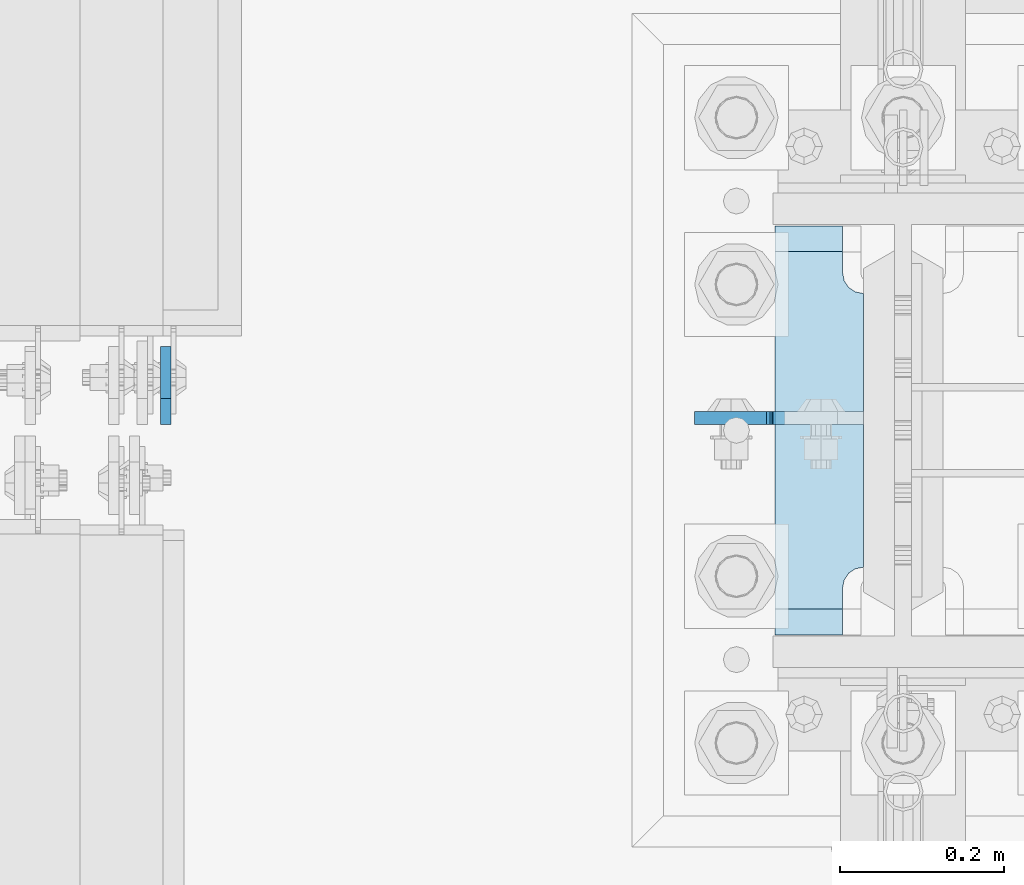
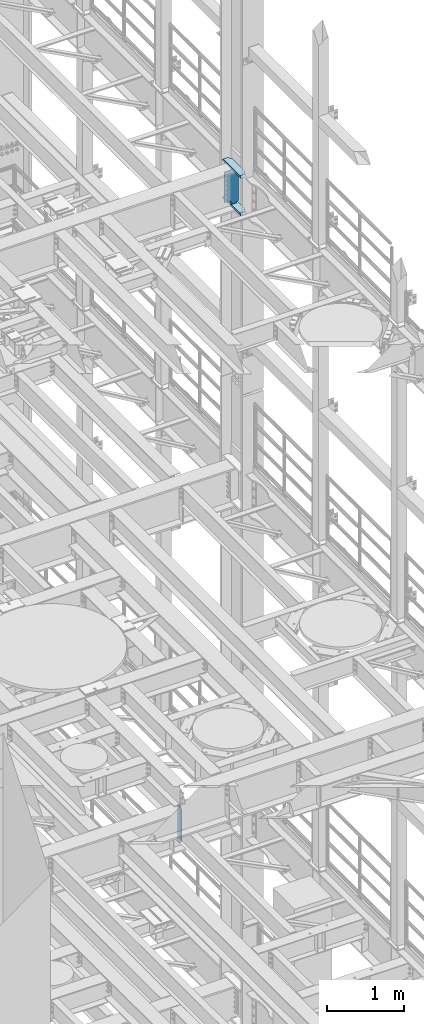
# One storey, part 1734 of 1876: 4 plates, 2 elements without a shape of their own.
"""IFC2X3 building model written with IfcOpenShell, lengths in millimetres."""

from ifc_helpers import new_model, si_unit, frame, origin_with_axes, place, context, subcontext, project, spatial, faceted_brep, material, type_object, element, aggregate, save


model = new_model("IFC2X3")

# Units and contexts
model_context = context("Model", 3, precision=1e-05, world=origin_with_axes())
body_context = subcontext(model_context, "Body", "Model", "MODEL_VIEW")
ifc_project = project(units=[si_unit("LENGTHUNIT", "METRE", prefix="MILLI"), si_unit("AREAUNIT", "SQUARE_METRE"), si_unit("VOLUMEUNIT", "CUBIC_METRE"), si_unit("MASSUNIT", "GRAM", prefix="KILO"), si_unit("TIMEUNIT", "SECOND"), si_unit("PLANEANGLEUNIT", "RADIAN"), si_unit("SOLIDANGLEUNIT", "STERADIAN"), si_unit("THERMODYNAMICTEMPERATUREUNIT", "DEGREE_CELSIUS"), si_unit("LUMINOUSINTENSITYUNIT", "LUMEN")], contexts=[model_context])

# Site, building, storey
site_placement = place(None, origin_with_axes())
site = spatial("IfcSite", under=ifc_project, at=site_placement, CompositionType="ELEMENT")
building_placement = place(site_placement, origin_with_axes())
building = spatial("IfcBuilding", under=site, at=building_placement, Name="Undefined", CompositionType="ELEMENT")
storey_placement = place(building_placement, origin_with_axes())
storey = spatial("IfcBuildingStorey", under=building, at=storey_placement, Name="Undefined", CompositionType="ELEMENT", Elevation=0.0)

# Assembly, plate
assembly_1_placement = place(storey_placement, origin_with_axes())
assembly_1 = element("IfcElementAssembly", 1, at=assembly_1_placement, inside=storey, Name="BEAM", AssemblyPlace="NOTDEFINED", PredefinedType="RIGID_FRAME")
ifc_material_1 = material(Name="STEEL/A36")
plate_type_1 = type_object("IfcPlateType", PredefinedType="NOTDEFINED")
plate_1_placement = place(assembly_1_placement, frame((6721.47499990463, 7627.14375, 7558.0875), z_axis=(0.0, 0.0, 1.0), x_axis=(0.0, 1.0, 0.0)))
plate_1 = element("IfcPlate", 2, at=plate_1_placement, type_object=plate_type_1, material=ifc_material_1, Name="PLATE", context=body_context, shape_type="Brep", body=[
    faceted_brep([(0.0, -6.34999999999991, 31.75), (0.0, -6.35000000000036, 538.162475585938), (0.0, 6.35000000000036, 538.162475585938), (0.0, 6.34999999999991, 31.75), (31.75, -6.35000000000036, 569.912475585938), (31.75, 6.35000000000036, 569.912475585938), (95.25, -6.35000000000036, 569.912475585938), (95.25, 6.35000000000036, 569.912475585938), (95.25, -6.35000000000036, 0.0), (95.25, 6.35000000000036, 0.0), (31.75, -6.34999999999991, 0.0), (31.75, 6.34999999999991, 0.0)], [[[0, 1, 2, 3]], [[1, 4, 5, 2]], [[4, 6, 7, 5]], [[6, 8, 9, 7]], [[8, 10, 11, 9]], [[10, 0, 3, 11]], [[5, 7, 9, 11, 3, 2]], [[10, 8, 6, 4, 1, 0]]]),
])
aggregate(assembly_1, [plate_1])

# Assembly, plates
assembly_2_placement = place(storey_placement, origin_with_axes())
assembly_2 = element("IfcElementAssembly", 3, at=assembly_2_placement, inside=storey, Name="COLUMN", AssemblyPlace="NOTDEFINED", PredefinedType="RIGID_FRAME")
ifc_material_2 = material(Name="STEEL/A572-50")
plate_type_2 = type_object("IfcPlateType", PredefinedType="NOTDEFINED")
plate_2_placement = place(assembly_2_placement, frame((7463.63125, 7869.2375, 17376.775012207), z_axis=(0.0, -1.0, 0.0), x_axis=(1.0, 0.0, 0.0)))
plate_2 = element("IfcPlate", 4, at=plate_2_placement, type_object=plate_type_2, material=ifc_material_2, Name="PLATE", context=body_context, shape_type="Brep", body=[
    faceted_brep([(82.5499973297119, -15.875, 498.475006103516), (82.5499973297119, 15.875, 467.025007631571), (0.0, 15.875, 467.025007631571), (0.0, -15.875, 498.475006103516), (82.5499973297119, 15.875, 31.449998471945), (82.5499973297119, -15.875, 0.0), (0.0, -15.875, 0.0), (0.0, 15.875, 31.449998471945), (82.5499973297119, 15.875, 57.1500034332275), (82.5499973297119, -15.875, 57.1500034332275), (84.4834571748879, -15.875, 66.8701624693188), (84.4834571748879, 15.875, 66.8701624693188), (89.9894849758439, -15.875, 75.1105154056261), (89.9894849758439, 15.875, 75.1105154056261), (98.2298379121512, -15.875, 80.616543206582), (98.2298379121512, 15.875, 80.616543206582), (107.949996948242, -15.875, 82.5500030517578), (107.949996948242, 15.875, 82.5500030517578), (107.949996948242, -15.875, 415.925003051758), (107.949996948242, 15.875, 415.925003051758), (98.2298379121512, -15.875, 417.858462896934), (98.2298379121512, 15.875, 417.858462896934), (89.9894849758439, -15.875, 423.36449069789), (89.9894849758439, 15.875, 423.36449069789), (84.483457174887, -15.875, 431.604843634197), (84.483457174887, 15.875, 431.604843634197), (82.5499973297119, -15.875, 441.325002670288), (82.5499973297119, 15.875, 441.325002670288)], [[[0, 1, 2, 3]], [[4, 5, 6, 7]], [[8, 9, 5, 4]], [[10, 9, 8, 11]], [[12, 10, 11, 13]], [[14, 12, 13, 15]], [[16, 14, 15, 17]], [[18, 16, 17, 19]], [[20, 18, 19, 21]], [[22, 20, 21, 23]], [[24, 22, 23, 25]], [[26, 24, 25, 27]], [[6, 5, 9, 10, 12, 14, 16, 18, 20, 22, 24, 26, 0, 3]], [[7, 6, 3, 2]], [[27, 25, 23, 21, 19, 17, 15, 13, 11, 8, 4, 7, 2, 1]], [[26, 27, 1, 0]]]),
])
plate_3_placement = place(assembly_2_placement, frame((7463.63125, 7869.2375, 17967.325), z_axis=(0.0, -1.0, 0.0), x_axis=(1.0, 0.0, 0.0)))
plate_3 = element("IfcPlate", 5, at=plate_3_placement, type_object=plate_type_2, material=ifc_material_2, Name="PLATE", context=body_context, shape_type="Brep", body=[
    faceted_brep([(82.5499973297119, -15.875, 498.475006103516), (82.5499973297119, 15.875, 467.025007631571), (0.0, 15.875, 467.025007631571), (0.0, -15.875, 498.475006103516), (82.5499973297119, 15.875, 31.449998471945), (82.5499973297119, -15.875, 0.0), (0.0, -15.875, 0.0), (0.0, 15.875, 31.449998471945), (82.5499973297119, 15.875, 57.1500034332275), (82.5499973297119, -15.875, 57.1500034332275), (84.4834571748879, -15.875, 66.8701624693188), (84.4834571748879, 15.875, 66.8701624693188), (89.9894849758439, -15.875, 75.1105154056261), (89.9894849758439, 15.875, 75.1105154056261), (98.2298379121512, -15.875, 80.616543206582), (98.2298379121512, 15.875, 80.616543206582), (107.949996948242, -15.875, 82.5500030517578), (107.949996948242, 15.875, 82.5500030517578), (107.949996948242, -15.875, 415.925003051758), (107.949996948242, 15.875, 415.925003051758), (98.2298379121512, -15.875, 417.858462896934), (98.2298379121512, 15.875, 417.858462896934), (89.9894849758439, -15.875, 423.36449069789), (89.9894849758439, 15.875, 423.36449069789), (84.483457174887, -15.875, 431.604843634197), (84.483457174887, 15.875, 431.604843634197), (82.5499973297119, -15.875, 441.325002670288), (82.5499973297119, 15.875, 441.325002670288)], [[[0, 1, 2, 3]], [[4, 5, 6, 7]], [[8, 9, 5, 4]], [[10, 9, 8, 11]], [[12, 10, 11, 13]], [[14, 12, 13, 15]], [[16, 14, 15, 17]], [[18, 16, 17, 19]], [[20, 18, 19, 21]], [[22, 20, 21, 23]], [[24, 22, 23, 25]], [[26, 24, 25, 27]], [[6, 5, 9, 10, 12, 14, 16, 18, 20, 22, 24, 26, 0, 3]], [[7, 6, 3, 2]], [[27, 25, 23, 21, 19, 17, 15, 13, 11, 8, 4, 7, 2, 1]], [[26, 27, 1, 0]]]),
])
plate_type_3 = type_object("IfcPlateType", PredefinedType="NOTDEFINED")
plate_4_placement = place(assembly_2_placement, frame((7571.58125, 7635.08125, 17951.45), z_axis=(-1.0, 0.0, 0.0), x_axis=(0.0, 0.0, -1.0)))
plate_4 = element("IfcPlate", 6, at=plate_4_placement, type_object=plate_type_3, material=ifc_material_1, Name="PLATE", context=body_context, shape_type="Brep", body=[
    faceted_brep([(19.0499992370605, -7.9375, 205.58125), (19.0499992370605, 7.9375, 205.581253051758), (19.0499992370605, 7.9375, 123.031249809265), (19.0499992370605, -7.9375, 123.031249809265), (18.083269314473, 7.9375, 118.17117029122), (18.083269314473, -7.9375, 118.17117029122), (15.3302554139955, 7.9375, 114.050993823066), (15.3302554139955, -7.9375, 114.050993823066), (11.2100789458418, 7.9375, 111.297979922588), (11.2100789458418, -7.9375, 111.297979922588), (6.34999942779541, 7.9375, 110.33125), (6.34999942779541, -7.9375, 110.33125), (0.0, 7.9375, 110.33125), (0.0, -7.9375, 110.33125), (0.0, 7.93749999999999, 31.75), (0.0, -7.93749999999998, 31.75), (31.75, -7.93749999999998, 0.0), (31.75, 7.93749999999999, 0.0), (527.049987792969, -7.93749999999998, 0.0), (527.049987792969, 7.93749999999999, 0.0), (558.799987792969, -7.93749999999998, 31.75), (558.799987792969, 7.93749999999999, 31.75), (558.799987792969, 7.9375, 110.331246948243), (558.799987792969, -7.9375, 110.331246948243), (509.489932498251, -7.9375, 111.297976870831), (505.369756030097, -7.9375, 114.050990771309), (502.61674212962, -7.9375, 118.171167239463), (501.650012207032, -7.9375, 123.031246757509), (501.650012207032, -7.9375, 205.581252728631), (514.350012016297, -7.9375, 110.331246948243), (502.61674212962, 7.9375, 118.171167239463), (501.650012207032, 7.9375, 123.031246757509), (505.369756030097, 7.9375, 114.050990771309), (509.489932498251, 7.9375, 111.297976870831), (514.350012016297, 7.9375, 110.331246948243), (501.650012207032, 7.9375, 205.581253051758)], [[[0, 1, 2, 3]], [[3, 2, 4, 5]], [[5, 4, 6, 7]], [[7, 6, 8, 9]], [[9, 8, 10, 11]], [[11, 10, 12, 13]], [[14, 15, 13, 12]], [[16, 15, 14, 17]], [[18, 16, 17, 19]], [[20, 18, 19, 21]], [[20, 21, 22, 23]], [[24, 25, 26, 27, 28, 0, 3, 5, 7, 9, 11, 13, 15, 16, 18, 20, 23, 29]], [[26, 30, 31, 27]], [[25, 32, 30, 26]], [[24, 33, 32, 25]], [[29, 34, 33, 24]], [[23, 22, 34, 29]], [[21, 19, 17, 14, 12, 10, 8, 6, 4, 2, 1, 35, 31, 30, 32, 33, 34, 22]], [[28, 27, 31, 35]], [[1, 0, 28, 35]]]),
])
aggregate(assembly_2, [plate_2, plate_3, plate_4])

save(model, "model.ifc")
